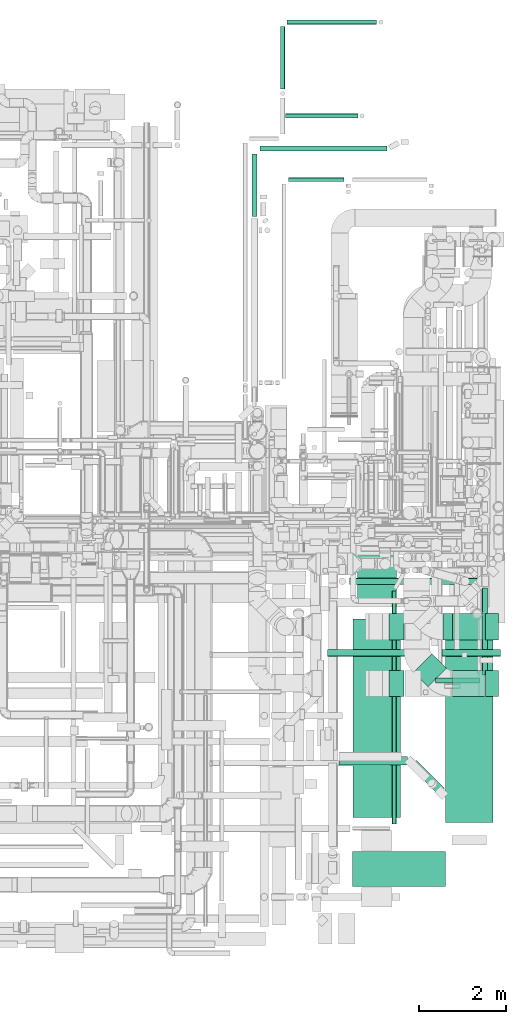
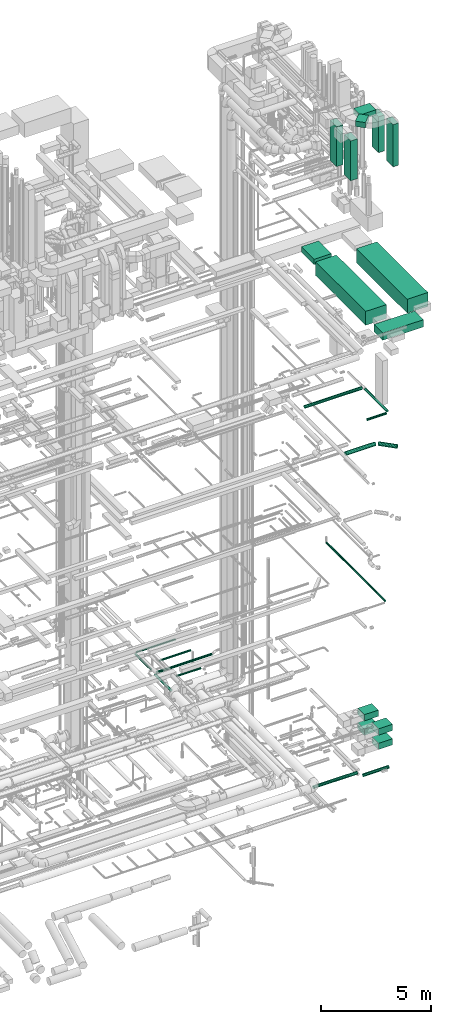
# One storey, part 81 of 337: 28 flow segments.
"""IFC2X3 building model written with IfcOpenShell, lengths in millimetres."""

import ifcopenshell
import ifcopenshell.guid

model = None  # the IFC model being written
_history = None  # IfcOwnerHistory: only IFC2X3 demands one
_inside = {}  # id of a spatial element -> (the spatial element, [elements in it])
_under = {}  # id of a project, library or spatial element -> (it, [spatial elements below it])
_declared = {}  # id of a project -> (the project, [libraries it declares])
_typed = {}  # id of a type object -> (the type object, [elements of that type])
_made_of = {}  # id of a material, layer set ... -> (it, [elements and type objects made of it])


def new_model(schema):
    """Start an empty IFC model of exactly this schema.

    Asked for "IFC4X3", IfcOpenShell would pick the latest addendum, in which some entities
    have other attributes; the version numbers below select the first issue.
    IFC2X3 requires an IfcOwnerHistory on every rooted entity: one is made here for all.
    """
    global model, _history
    if schema == "IFC4X3":
        model = ifcopenshell.file(schema_version=(4, 3, 0, 0))
    else:
        model = ifcopenshell.file(schema=schema)
    _inside.clear()
    _under.clear()
    _declared.clear()
    _typed.clear()
    _made_of.clear()
    _history = None
    if model.schema == "IFC2X3":
        org = make("IfcOrganization", Name="unknown")
        user = make(
            "IfcPersonAndOrganization",
            ThePerson=make("IfcPerson", FamilyName="unknown"),
            TheOrganization=org,
        )
        app = make(
            "IfcApplication",
            ApplicationDeveloper=org,
            Version="unknown",
            ApplicationFullName="unknown",
            ApplicationIdentifier="unknown",
        )
        _history = make(
            "IfcOwnerHistory",
            OwningUser=user,
            OwningApplication=app,
            ChangeAction="ADDED",
            CreationDate=0,
        )
    return model


def make(cls, **values):
    """One entity of the class cls with the attributes given. An attribute that is None is left unset."""
    return model.create_entity(
        cls, **{name: value for name, value in values.items() if value is not None}
    )


def entity(cls, *values):
    """Any entity or typed value of the class cls, its attributes in the order of the schema. None: left unset."""
    e = model.create_entity(cls)
    for i, value in enumerate(values):
        if value is not None:
            e[i] = value
    return e


def rooted(cls, **values):
    """An entity with a GlobalId (a new one), such as an element, a storey or a relation."""
    return make(cls, GlobalId=ifcopenshell.guid.new(), OwnerHistory=_history, **values)


def si_unit(unit_type, name, prefix=None):
    """IfcSIUnit, for example si_unit("LENGTHUNIT", "METRE", prefix="MILLI")."""
    return make("IfcSIUnit", UnitType=unit_type, Prefix=prefix, Name=name)


def converted_unit(unit_type, name, factor, base, dimensions=None, offset=None):
    """IfcConversionBasedUnit, such as the inch: factor (a typed value) times the base unit."""
    return make(
        "IfcConversionBasedUnit"
        if offset is None
        else "IfcConversionBasedUnitWithOffset",
        ConversionOffset=offset,
        Dimensions=None
        if dimensions is None
        else entity("IfcDimensionalExponents", *dimensions),
        UnitType=unit_type,
        Name=name,
        ConversionFactor=make(
            "IfcMeasureWithUnit", ValueComponent=factor, UnitComponent=base
        ),
    )


def derived_unit(unit_type, elements):
    """IfcDerivedUnit: a product of units, each with its exponent."""
    return make(
        "IfcDerivedUnit",
        Elements=[
            make("IfcDerivedUnitElement", Unit=unit, Exponent=power)
            for unit, power in elements
        ],
        UnitType=unit_type,
    )


def assignment(units):
    """IfcUnitAssignment: the units of a project."""
    return None if units is None else make("IfcUnitAssignment", Units=units)


def point(xyz):
    """IfcCartesianPoint."""
    return None if xyz is None else make("IfcCartesianPoint", Coordinates=xyz)


def direction(xyz):
    """IfcDirection."""
    return None if xyz is None else make("IfcDirection", DirectionRatios=xyz)


def frame(location, z_axis=None, x_axis=None):
    """IfcAxis2Placement3D, a coordinate frame: its origin and axes. An axis left out is left unset."""
    return make(
        "IfcAxis2Placement3D",
        Location=point(location),
        Axis=direction(z_axis),
        RefDirection=direction(x_axis),
    )


def frame_2d(location, x_axis=None):
    """IfcAxis2Placement2D, a coordinate frame in the plane: its origin and x axis."""
    return make(
        "IfcAxis2Placement2D", Location=point(location), RefDirection=direction(x_axis)
    )


def origin():
    """The frame at (0, 0, 0) with its axes left unset."""
    return frame((0.0, 0.0, 0.0))


def origin_2d_with_axis():
    """The frame at (0, 0) in the plane with the x axis (1, 0) written out."""
    return frame_2d((0.0, 0.0), x_axis=(1.0, 0.0))


def place(relative_to, where):
    """IfcLocalPlacement: puts the frame where relative to a parent placement (None: the world)."""
    return make(
        "IfcLocalPlacement", PlacementRelTo=relative_to, RelativePlacement=where
    )


def context(
    kind, dimensions, precision=None, world=None, true_north=None, identifier=None
):
    """IfcGeometricRepresentationContext, for example the 3D "Model" context."""
    return make(
        "IfcGeometricRepresentationContext",
        ContextIdentifier=identifier,
        ContextType=kind,
        CoordinateSpaceDimension=dimensions,
        Precision=precision,
        WorldCoordinateSystem=world,
        TrueNorth=true_north,
    )


def subcontext(parent, identifier, kind, view, scale=None):
    """IfcGeometricRepresentationSubContext, for example "Body" below "Model"."""
    return make(
        "IfcGeometricRepresentationSubContext",
        ContextIdentifier=identifier,
        ContextType=kind,
        ParentContext=parent,
        TargetScale=scale,
        TargetView=view,
    )


def project(units=None, contexts=None):
    """IfcProject with its units and contexts."""
    return rooted(
        "IfcProject",
        Name="project",
        RepresentationContexts=contexts,
        UnitsInContext=assignment(units),
    )


def spatial(cls, under=None, at=None, **own):
    """A site, building, storey or space (cls), placed at a placement, below another one or the project."""
    s = rooted(cls, ObjectPlacement=at, **own)
    if under is not None:
        _under.setdefault(under.id(), (under, []))[1].append(s)
    return s


def profile(cls, at=None, kind="AREA", **sizes):
    """A parametric profile (cls). Its sizes go by their IFC names, for example OverallWidth=200.0."""
    return make(cls, ProfileType=kind, Position=at, **sizes)


def rectangle(**sizes):
    """IfcRectangleProfileDef."""
    return profile("IfcRectangleProfileDef", **sizes)


def circle(**sizes):
    """IfcCircleProfileDef."""
    return profile("IfcCircleProfileDef", **sizes)


def extrude(swept, where, along, depth):
    """IfcExtrudedAreaSolid: the profile swept, set in the frame where, extruded along a direction by depth."""
    return make(
        "IfcExtrudedAreaSolid",
        SweptArea=swept,
        Position=where,
        ExtrudedDirection=direction(along),
        Depth=depth,
    )


def shape(context_of_items, identifier, shape_type, items):
    """IfcShapeRepresentation: the items that make up one representation, for example the "Body"."""
    return make(
        "IfcShapeRepresentation",
        ContextOfItems=context_of_items,
        RepresentationIdentifier=identifier,
        RepresentationType=shape_type,
        Items=items,
    )


def made_of(thing, what):
    """Note that an element or type object is made of a material, layer set ...; save() writes the relation."""
    if what is not None:
        _made_of.setdefault(what.id(), (what, []))[1].append(thing)
    return thing


def type_object(cls, material=None, **own):
    """A type object (cls), such as IfcWallType, which elements share."""
    return made_of(rooted(cls, **own), material)


def element(
    cls,
    number,
    at=None,
    inside=None,
    cuts=None,
    type_object=None,
    material=None,
    context=None,
    identifier="Body",
    shape_type=None,
    held_by="IfcProductDefinitionShape",
    body=None,
    shapes=None,
    **own,
):
    """One element of the class cls, such as IfcWall. Its Tag is "e" and its number.

    at: its placement. inside: the storey or other place that contains it. cuts: it is an
    opening in that element (IfcRelVoidsElement). A single representation is given by context,
    identifier, shape_type and body (its items); several are given by shapes. held_by: the class
    of the entity that holds the representations. save() writes the other relations.
    """
    e = rooted(cls, Tag="e%d" % number, ObjectPlacement=at, **own)
    if body is not None:
        shapes = [shape(context, identifier, shape_type, body)]
    if shapes is not None:
        e.Representation = make(held_by, Representations=shapes)
    if inside is not None:
        _inside.setdefault(inside.id(), (inside, []))[1].append(e)
    if cuts is not None:
        rooted(
            "IfcRelVoidsElement", RelatingBuildingElement=cuts, RelatedOpeningElement=e
        )
    if type_object is not None:
        _typed.setdefault(type_object.id(), (type_object, []))[1].append(e)
    return made_of(e, material)


def aggregate(whole, parts):
    """IfcRelAggregates: a whole, such as a stair, and the parts it consists of."""
    return rooted("IfcRelAggregates", RelatingObject=whole, RelatedObjects=parts)


def save(model, path):
    """Write the relations noted so far, then the file.

    IfcRelAggregates (storeys below a building ...), IfcRelContainedInSpatialStructure (elements
    in a storey), IfcRelDefinesByType, IfcRelAssociatesMaterial and IfcRelDeclares: one each for
    every whole, place, type object, material and project.
    """
    for whole, parts in _under.values():
        aggregate(whole, parts)
    for where, things in _inside.values():
        rooted(
            "IfcRelContainedInSpatialStructure",
            RelatedElements=things,
            RelatingStructure=where,
        )
    for kind, things in _typed.values():
        rooted("IfcRelDefinesByType", RelatedObjects=things, RelatingType=kind)
    for what, things in _made_of.values():
        rooted("IfcRelAssociatesMaterial", RelatedObjects=things, RelatingMaterial=what)
    for by, libraries in _declared.values():
        rooted("IfcRelDeclares", RelatingContext=by, RelatedDefinitions=libraries)
    model.write(path)


model = new_model("IFC2X3")

# Units and contexts
model_context = context("Model", 3, precision=0.01, world=origin(), true_north=direction((6.12303176911189e-17, 1.0)))
body_context = subcontext(model_context, "Body", "Model", "MODEL_VIEW")
ifc_project = project(units=[si_unit("LENGTHUNIT", "METRE", prefix="MILLI"), si_unit("AREAUNIT", "SQUARE_METRE"), si_unit("VOLUMEUNIT", "CUBIC_METRE"), converted_unit("PLANEANGLEUNIT", "DEGREE", entity("IfcRatioMeasure", 0.0174532925199433), si_unit("PLANEANGLEUNIT", "RADIAN"), dimensions=[0, 0, 0, 0, 0, 0, 0]), si_unit("MASSUNIT", "GRAM", prefix="KILO"), derived_unit("MASSDENSITYUNIT", [(si_unit("MASSUNIT", "GRAM", prefix="KILO"), 1), (si_unit("LENGTHUNIT", "METRE"), -3)]), derived_unit("MOMENTOFINERTIAUNIT", [(si_unit("LENGTHUNIT", "METRE"), 4)]), si_unit("TIMEUNIT", "SECOND"), si_unit("FREQUENCYUNIT", "HERTZ"), si_unit("THERMODYNAMICTEMPERATUREUNIT", "DEGREE_CELSIUS"), derived_unit("THERMALTRANSMITTANCEUNIT", [(si_unit("MASSUNIT", "GRAM", prefix="KILO"), 1), (si_unit("THERMODYNAMICTEMPERATUREUNIT", "KELVIN"), -1), (si_unit("TIMEUNIT", "SECOND"), -3)]), derived_unit("VOLUMETRICFLOWRATEUNIT", [(si_unit("LENGTHUNIT", "METRE"), 3), (si_unit("TIMEUNIT", "SECOND"), -1)]), derived_unit("MASSFLOWRATEUNIT", [(si_unit("MASSUNIT", "GRAM", prefix="KILO"), 1), (si_unit("TIMEUNIT", "SECOND"), -1)]), derived_unit("ROTATIONALFREQUENCYUNIT", [(si_unit("TIMEUNIT", "SECOND"), -1)]), si_unit("ELECTRICCURRENTUNIT", "AMPERE"), si_unit("ELECTRICVOLTAGEUNIT", "VOLT"), si_unit("POWERUNIT", "WATT"), si_unit("FORCEUNIT", "NEWTON", prefix="KILO"), si_unit("ILLUMINANCEUNIT", "LUX"), si_unit("LUMINOUSFLUXUNIT", "LUMEN"), si_unit("LUMINOUSINTENSITYUNIT", "CANDELA"), derived_unit("USERDEFINED", [(si_unit("MASSUNIT", "GRAM", prefix="KILO"), -1), (si_unit("LENGTHUNIT", "METRE"), -2), (si_unit("TIMEUNIT", "SECOND"), 3), (si_unit("LUMINOUSFLUXUNIT", "LUMEN"), 1)]), derived_unit("LINEARVELOCITYUNIT", [(si_unit("LENGTHUNIT", "METRE"), 1), (si_unit("TIMEUNIT", "SECOND"), -1)]), si_unit("PRESSUREUNIT", "PASCAL"), derived_unit("USERDEFINED", [(si_unit("LENGTHUNIT", "METRE"), -2), (si_unit("MASSUNIT", "GRAM", prefix="KILO"), 1), (si_unit("TIMEUNIT", "SECOND"), -2)]), derived_unit("LINEARFORCEUNIT", [(si_unit("MASSUNIT", "GRAM", prefix="KILO"), 1), (si_unit("LENGTHUNIT", "METRE"), 1), (si_unit("TIMEUNIT", "SECOND"), -2), (si_unit("LENGTHUNIT", "METRE"), -1)]), derived_unit("PLANARFORCEUNIT", [(si_unit("MASSUNIT", "GRAM", prefix="KILO"), 1), (si_unit("LENGTHUNIT", "METRE"), 1), (si_unit("TIMEUNIT", "SECOND"), -2), (si_unit("LENGTHUNIT", "METRE"), -2)])], contexts=[model_context])

# Site, building, storey
site_placement = place(None, origin())
site = spatial("IfcSite", under=ifc_project, at=site_placement, CompositionType="ELEMENT")
building_placement = place(site_placement, origin())
building = spatial("IfcBuilding", under=site, at=building_placement, CompositionType="ELEMENT")
storey_placement = place(building_placement, origin())
storey = spatial("IfcBuildingStorey", under=building, at=storey_placement, CompositionType="ELEMENT", Elevation=0.0)

# Flow segments
duct_segment_type_1 = type_object("IfcDuctSegmentType", PredefinedType="NOTDEFINED")
flow_segment_1_placement = place(storey_placement, frame((69853.15, 8227.29, 27350.0)))
element("IfcFlowSegment", 1, at=flow_segment_1_placement, inside=storey, type_object=duct_segment_type_1, context=body_context, shape_type="SweptSolid", body=[
    extrude(rectangle(XDim=1166.69047558346, YDim=900.000000000003, at=origin_2d_with_axis()), frame((450.0, 583.35, 0.0), z_axis=(0.0, 0.0, 1.0), x_axis=(0.0, 1.0, 0.0)), (0.0, 0.0, 1.0), 300.000000000001),
])
flow_segment_2_placement = place(storey_placement, frame((70576.93, 6153.72, 33010.0)))
element("IfcFlowSegment", 2, at=flow_segment_2_placement, inside=storey, type_object=duct_segment_type_1, context=body_context, shape_type="SweptSolid", body=[
    extrude(rectangle(XDim=600.0, YDim=349.999999999998, at=origin_2d_with_axis()), frame((175.0, 300.0, 0.0), z_axis=(0.0, 0.0, 1.0), x_axis=(0.0, 1.0, 0.0)), (0.0, 0.0, 1.0), 2214.99999999999),
])
flow_segment_3_placement = place(storey_placement, frame((72796.93, 6153.72, 33010.0)))
element("IfcFlowSegment", 3, at=flow_segment_3_placement, inside=storey, type_object=duct_segment_type_1, context=body_context, shape_type="SweptSolid", body=[
    extrude(rectangle(XDim=300.000000000001, YDim=600.0, at=origin_2d_with_axis()), frame((150.0, 300.0, 0.0), z_axis=(0.0, 0.0, 1.0), x_axis=(-1.0, 0.0, 0.0)), (0.0, 0.0, 1.0), 2339.99999999998),
])
for number, where in (
    (4, (72041.24, 6153.72, 895.71)),
    (5, (72041.24, 6153.72, 1695.71)),
):
    element("IfcFlowSegment", number, at=place(storey_placement, frame(where)), inside=storey, type_object=duct_segment_type_1, context=body_context, shape_type="SweptSolid", body=[
        extrude(rectangle(XDim=735.698442000009, YDim=600.0, at=origin_2d_with_axis()), frame((367.85, 300.0, 0.0), z_axis=(0.0, 0.0, 1.0), x_axis=(-1.0, 0.0, 0.0)), (0.0, 0.0, 1.0), 350.0),
    ])
flow_segment_4_placement = place(storey_placement, frame((71139.42, 6373.39, 35500.0)))
element("IfcFlowSegment", 6, at=flow_segment_4_placement, inside=storey, type_object=duct_segment_type_1, context=body_context, shape_type="SweptSolid", body=[
    extrude(rectangle(XDim=475.766968229204, YDim=600.000000000003, at=origin_2d_with_axis()), frame((380.34, 380.34, 0.0), z_axis=(0.0, 0.0, 1.0), x_axis=(-0.707106781186541, 0.707106781186554, 0.0)), (0.0, 0.0, 1.0), 300.000000000001),
])
flow_segment_5_placement = place(storey_placement, frame((70576.93, 7453.68, 33010.0)))
element("IfcFlowSegment", 7, at=flow_segment_5_placement, inside=storey, type_object=duct_segment_type_1, context=body_context, shape_type="SweptSolid", body=[
    extrude(rectangle(XDim=600.0, YDim=349.999999999998, at=origin_2d_with_axis()), frame((175.0, 300.0, 0.0), z_axis=(0.0, 0.0, 1.0), x_axis=(0.0, 1.0, 0.0)), (0.0, 0.0, 1.0), 2214.99999999998),
])
flow_segment_6_placement = place(storey_placement, frame((72796.93, 7453.68, 33010.0)))
element("IfcFlowSegment", 8, at=flow_segment_6_placement, inside=storey, type_object=duct_segment_type_1, context=body_context, shape_type="SweptSolid", body=[
    extrude(rectangle(XDim=300.000000000001, YDim=600.0, at=origin_2d_with_axis()), frame((150.0, 300.0, 0.0), z_axis=(0.0, 0.0, 1.0), x_axis=(-1.0, 0.0, 0.0)), (0.0, 0.0, 1.0), 1989.99999999996),
])
flow_segment_7_placement = place(storey_placement, frame((71820.86, 7453.68, 35150.0)))
element("IfcFlowSegment", 9, at=flow_segment_7_placement, inside=storey, type_object=duct_segment_type_1, context=body_context, shape_type="SweptSolid", body=[
    extrude(rectangle(XDim=826.070307051706, YDim=600.0, at=origin_2d_with_axis()), frame((413.04, 300.0, 0.0), z_axis=(0.0, 0.0, 1.0), x_axis=(-1.0, 0.0, 0.0)), (0.0, 0.0, 1.0), 300.000000000001),
])
flow_segment_8_placement = place(storey_placement, frame((72041.24, 7453.68, 1695.71)))
element("IfcFlowSegment", 10, at=flow_segment_8_placement, inside=storey, type_object=duct_segment_type_1, context=body_context, shape_type="SweptSolid", body=[
    extrude(rectangle(XDim=735.698442000026, YDim=600.0, at=origin_2d_with_axis()), frame((367.85, 300.0, 0.0)), (0.0, 0.0, 1.0), 350.0),
])
flow_segment_9_placement = place(storey_placement, frame((72041.24, 7453.68, 895.71)))
element("IfcFlowSegment", 11, at=flow_segment_9_placement, inside=storey, type_object=duct_segment_type_1, context=body_context, shape_type="SweptSolid", body=[
    extrude(rectangle(XDim=735.698442, YDim=600.0, at=origin_2d_with_axis()), frame((367.85, 300.0, 0.0)), (0.0, 0.0, 1.0), 350.0),
])
flow_segment_10_placement = place(storey_placement, frame((69744.47, 1793.41, 27085.0)))
element("IfcFlowSegment", 12, at=flow_segment_10_placement, inside=storey, type_object=duct_segment_type_1, context=body_context, shape_type="SweptSolid", body=[
    extrude(rectangle(XDim=2129.66242915282, YDim=800.0, at=origin_2d_with_axis()), frame((1064.83, 400.0, 0.0)), (0.0, 0.0, 1.0), 400.000000000004),
])
flow_segment_11_placement = place(storey_placement, frame((69758.15, 3379.37, 26955.0)))
element("IfcFlowSegment", 13, at=flow_segment_11_placement, inside=storey, type_object=duct_segment_type_1, context=body_context, shape_type="SweptSolid", body=[
    extrude(rectangle(XDim=4547.92298366807, YDim=1090.0, at=origin_2d_with_axis()), frame((545.0, 2273.96, 0.0), z_axis=(0.0, 0.0, 1.0), x_axis=(0.0, 1.0, 0.0)), (0.0, 0.0, 1.0), 769.999999999998),
])
flow_segment_12_placement = place(storey_placement, frame((71879.33, 3263.26, 26955.0)))
element("IfcFlowSegment", 14, at=flow_segment_12_placement, inside=storey, type_object=duct_segment_type_1, context=body_context, shape_type="SweptSolid", body=[
    extrude(rectangle(XDim=4643.87797391152, YDim=1090.0, at=origin_2d_with_axis()), frame((545.66, 2322.09, 0.0), z_axis=(0.0, 0.0, 1.0), x_axis=(-0.000284713724846014, -0.999999959469047, 0.0)), (0.0, 0.0, 1.0), 769.999999999998),
])
duct_segment_type_2 = type_object("IfcDuctSegmentType", PredefinedType="NOTDEFINED")
flow_segment_13_placement = place(storey_placement, frame((69174.5, 7073.15, -881.6)))
element("IfcFlowSegment", 15, at=flow_segment_13_placement, inside=storey, type_object=duct_segment_type_2, context=body_context, shape_type="SweptSolid", body=[
    extrude(circle(Radius=80.0, at=origin_2d_with_axis()), frame((0.0, 81.6, 81.6), z_axis=(1.0, 0.0, 0.0), x_axis=(0.0, 1.0, 0.0)), (0.0, 0.0, 1.0), 2315.5989972419),
])
flow_segment_14_placement = place(storey_placement, frame((71799.04, 7069.56, -1131.6)))
element("IfcFlowSegment", 16, at=flow_segment_14_placement, inside=storey, type_object=duct_segment_type_2, context=body_context, shape_type="SweptSolid", body=[
    extrude(circle(Radius=80.0, at=origin_2d_with_axis()), frame((0.0, 81.6, 81.6), z_axis=(1.0, 0.0, 0.0), x_axis=(0.0, -1.0, 0.0)), (0.0, 0.0, 1.0), 1340.00000000001),
])
flow_segment_15_placement = place(storey_placement, frame((67430.11, 17167.04, -964.1)))
element("IfcFlowSegment", 17, at=flow_segment_15_placement, inside=storey, type_object=duct_segment_type_2, context=body_context, shape_type="SweptSolid", body=[
    extrude(circle(Radius=62.5, at=origin_2d_with_axis()), frame((64.1, 0.0, 64.1), z_axis=(0.0, 1.0, 0.0), x_axis=(1.0, 0.0, 0.0)), (0.0, 0.0, 1.0), 1442.08924316945),
])
flow_segment_16_placement = place(storey_placement, frame((67619.2, 18670.03, -964.1)))
element("IfcFlowSegment", 18, at=flow_segment_16_placement, inside=storey, type_object=duct_segment_type_2, context=body_context, shape_type="SweptSolid", body=[
    extrude(circle(Radius=62.5, at=origin_2d_with_axis()), frame((0.0, 64.1, 64.1), z_axis=(1.0, 0.0, 0.0), x_axis=(0.0, -1.0, 0.0)), (0.0, 0.0, 1.0), 2913.82944547093),
])
flow_segment_17_placement = place(storey_placement, frame((68209.38, 19431.52, -951.6)))
element("IfcFlowSegment", 19, at=flow_segment_17_placement, inside=storey, type_object=duct_segment_type_2, context=body_context, shape_type="SweptSolid", body=[
    extrude(circle(Radius=50.0, at=origin_2d_with_axis()), frame((0.0, 51.6, 51.6), z_axis=(1.0, 0.0, 0.0), x_axis=(0.0, -1.0, 0.0)), (0.0, 0.0, 1.0), 1654.82764999997),
])
flow_segment_18_placement = place(storey_placement, frame((68087.78, 20097.11, -1801.6)))
element("IfcFlowSegment", 20, at=flow_segment_18_placement, inside=storey, type_object=duct_segment_type_2, context=body_context, shape_type="SweptSolid", body=[
    extrude(circle(Radius=50.0, at=origin_2d_with_axis()), frame((51.6, 0.0, 51.6), z_axis=(0.0, 1.0, 0.0), x_axis=(-1.0, 0.0, 0.0)), (0.0, 0.0, 1.0), 1436.59545999999),
])
flow_segment_19_placement = place(storey_placement, frame((68239.38, 21582.11, -1801.6)))
element("IfcFlowSegment", 21, at=flow_segment_19_placement, inside=storey, type_object=duct_segment_type_2, context=body_context, shape_type="SweptSolid", body=[
    extrude(circle(Radius=50.0, at=origin_2d_with_axis()), frame((0.0, 51.6, 51.6), z_axis=(1.0, 0.0, 0.0), x_axis=(0.0, -1.0, 0.0)), (0.0, 0.0, 1.0), 2056.70079999999),
])
flow_segment_20_placement = place(storey_placement, frame((68269.32, 17971.54, -951.6)))
element("IfcFlowSegment", 22, at=flow_segment_20_placement, inside=storey, type_object=duct_segment_type_2, context=body_context, shape_type="SweptSolid", body=[
    extrude(circle(Radius=50.0, at=origin_2d_with_axis()), frame((0.0, 51.6, 51.6), z_axis=(1.0, 0.0, 0.0), x_axis=(0.0, -1.0, 0.0)), (0.0, 0.0, 1.0), 1279.63499999999),
])
flow_segment_21_placement = place(storey_placement, frame((70650.33, 3222.88, 11348.4)))
element("IfcFlowSegment", 23, at=flow_segment_21_placement, inside=storey, type_object=duct_segment_type_2, context=body_context, shape_type="SweptSolid", body=[
    extrude(circle(Radius=50.0, at=origin_2d_with_axis()), frame((51.6, 0.0, 51.6), z_axis=(0.0, 1.0, 0.0), x_axis=(1.0, 0.0, 0.0)), (0.0, 0.0, 1.0), 5353.20508075698),
])
flow_segment_22_placement = place(storey_placement, frame((69433.79, 4573.02, 19048.4)))
element("IfcFlowSegment", 24, at=flow_segment_22_placement, inside=storey, type_object=duct_segment_type_2, context=body_context, shape_type="SweptSolid", body=[
    extrude(circle(Radius=100.0, at=origin_2d_with_axis()), frame((0.0, 101.6, 101.6), z_axis=(1.0, 0.0, 0.0), x_axis=(0.0, -1.0, 0.0)), (0.0, 0.0, 1.0), 1567.15728752535),
])
flow_segment_23_placement = place(storey_placement, frame((71070.07, 3905.2, 19048.4)))
element("IfcFlowSegment", 25, at=flow_segment_23_placement, inside=storey, type_object=duct_segment_type_2, context=body_context, shape_type="SweptSolid", body=[
    extrude(circle(Radius=100.0, at=origin_2d_with_axis()), frame((710.83, 72.31, 101.6), z_axis=(-0.707106781186538, 0.707106781186557, 0.0), x_axis=(-0.707106781186557, -0.707106781186538, 0.0)), (0.0, 0.0, 1.0), 903.015151901689),
])
flow_segment_24_placement = place(storey_placement, frame((72720.06, 6645.45, 19085.9)))
element("IfcFlowSegment", 26, at=flow_segment_24_placement, inside=storey, type_object=duct_segment_type_2, context=body_context, shape_type="SweptSolid", body=[
    extrude(circle(Radius=62.5, at=origin_2d_with_axis()), frame((64.1, 0.0, 64.1), z_axis=(0.0, 1.0, 0.0), x_axis=(-1.0, 0.0, 0.0)), (0.0, 0.0, 1.0), 2003.12500000001),
])
flow_segment_25_placement = place(storey_placement, frame((71644.16, 6456.35, 19085.9)))
element("IfcFlowSegment", 27, at=flow_segment_25_placement, inside=storey, type_object=duct_segment_type_2, context=body_context, shape_type="SweptSolid", body=[
    extrude(circle(Radius=62.5, at=origin_2d_with_axis()), frame((0.0, 64.1, 64.1), z_axis=(1.0, 0.0, 0.0), x_axis=(0.0, 1.0, 0.0)), (0.0, 0.0, 1.0), 1015.00000000001),
])
flow_segment_26_placement = place(storey_placement, frame((69669.84, 8716.98, 19083.4)))
element("IfcFlowSegment", 28, at=flow_segment_26_placement, inside=storey, type_object=duct_segment_type_2, context=body_context, shape_type="SweptSolid", body=[
    extrude(circle(Radius=80.0, at=origin_2d_with_axis()), frame((0.0, 81.6, 81.6), z_axis=(1.0, 0.0, 0.0), x_axis=(0.0, -1.0, 0.0)), (0.0, 0.0, 1.0), 3015.73836612846),
])

save(model, "model.ifc")
